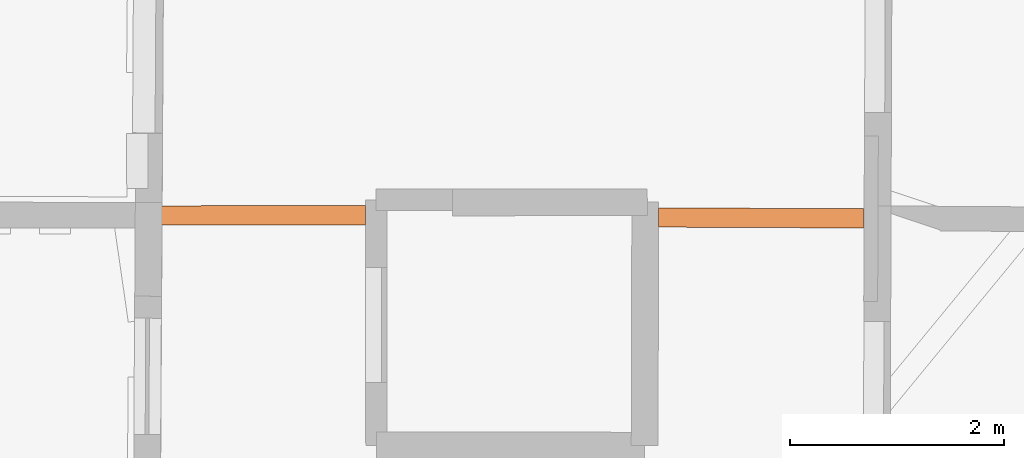
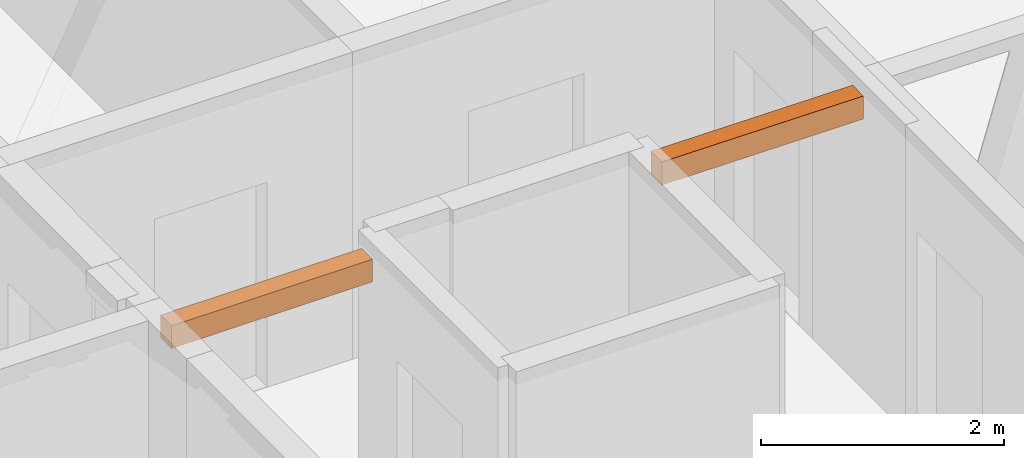
# One storey, part 15 of 15: 2 proxies.
"""IFC2X3 building model written with IfcOpenShell, lengths in metres."""

from ifc_helpers import new_model, entity, si_unit, converted_unit, derived_unit, direction, frame, origin, place, context, subcontext, project, spatial, polyline, outline, extrude, source, transform, mapped, material, type_object, type_shapes, element, save


model = new_model("IFC2X3")

# Units and contexts
model_context = context("Model", 3, precision=1e-05, world=origin(), true_north=direction((0.0, 1.0)))
body_context = subcontext(model_context, "Body", "Model", "MODEL_VIEW")
ifc_project = project(units=[si_unit("LENGTHUNIT", "METRE"), si_unit("AREAUNIT", "SQUARE_METRE"), si_unit("VOLUMEUNIT", "CUBIC_METRE"), converted_unit("PLANEANGLEUNIT", "DEGREE", entity("IfcRatioMeasure", 0.0174532925199433), si_unit("PLANEANGLEUNIT", "RADIAN"), dimensions=[0, 0, 0, 0, 0, 0, 0]), si_unit("MASSUNIT", "GRAM", prefix="KILO"), derived_unit("MASSDENSITYUNIT", [(si_unit("MASSUNIT", "GRAM", prefix="KILO"), 1), (si_unit("LENGTHUNIT", "METRE"), -3)]), derived_unit("MOMENTOFINERTIAUNIT", [(si_unit("LENGTHUNIT", "METRE"), 4)]), si_unit("TIMEUNIT", "SECOND"), si_unit("FREQUENCYUNIT", "HERTZ"), si_unit("THERMODYNAMICTEMPERATUREUNIT", "DEGREE_CELSIUS"), derived_unit("THERMALTRANSMITTANCEUNIT", [(si_unit("MASSUNIT", "GRAM", prefix="KILO"), 1), (si_unit("THERMODYNAMICTEMPERATUREUNIT", "KELVIN"), -1), (si_unit("TIMEUNIT", "SECOND"), -3)]), derived_unit("VOLUMETRICFLOWRATEUNIT", [(si_unit("LENGTHUNIT", "METRE"), 3), (si_unit("TIMEUNIT", "SECOND"), -1)]), si_unit("ELECTRICCURRENTUNIT", "AMPERE"), si_unit("ELECTRICVOLTAGEUNIT", "VOLT"), si_unit("POWERUNIT", "WATT"), si_unit("FORCEUNIT", "NEWTON", prefix="KILO"), si_unit("ILLUMINANCEUNIT", "LUX"), si_unit("LUMINOUSFLUXUNIT", "LUMEN"), si_unit("LUMINOUSINTENSITYUNIT", "CANDELA"), derived_unit("USERDEFINED", [(si_unit("MASSUNIT", "GRAM", prefix="KILO"), -1), (si_unit("LENGTHUNIT", "METRE"), -2), (si_unit("TIMEUNIT", "SECOND"), 3), (si_unit("LUMINOUSFLUXUNIT", "LUMEN"), 1)]), derived_unit("LINEARVELOCITYUNIT", [(si_unit("LENGTHUNIT", "METRE"), 1), (si_unit("TIMEUNIT", "SECOND"), -1)]), si_unit("PRESSUREUNIT", "PASCAL"), derived_unit("USERDEFINED", [(si_unit("LENGTHUNIT", "METRE"), -2), (si_unit("MASSUNIT", "GRAM", prefix="KILO"), 1), (si_unit("TIMEUNIT", "SECOND"), -2)]), derived_unit("LINEARFORCEUNIT", [(si_unit("MASSUNIT", "GRAM", prefix="KILO"), 1), (si_unit("LENGTHUNIT", "METRE"), 1), (si_unit("TIMEUNIT", "SECOND"), -2), (si_unit("LENGTHUNIT", "METRE"), -1)]), derived_unit("PLANARFORCEUNIT", [(si_unit("MASSUNIT", "GRAM", prefix="KILO"), 1), (si_unit("LENGTHUNIT", "METRE"), 1), (si_unit("TIMEUNIT", "SECOND"), -2), (si_unit("LENGTHUNIT", "METRE"), -2)])], contexts=[model_context])

# Site, building, storey
placement_1 = place(None, origin())
site = spatial("IfcSite", under=ifc_project, at=placement_1, CompositionType="ELEMENT")
building = spatial("IfcBuilding", under=site, at=placement_1, CompositionType="ELEMENT")
storey_placement = place(placement_1, frame((0.0, 0.0, 2.3807327747345)))
storey = spatial("IfcBuildingStorey", under=building, at=storey_placement, Name="Level 2", CompositionType="ELEMENT", Elevation=2.3807327747345)

# Proxies
ifc_material = material(Name="Beam default")
building_element_proxy_type_1 = type_object("IfcBuildingElementProxyType", Name="Beam:242", PredefinedType="NOTDEFINED")
shared_shape_1 = source(origin(), body_context, "Body", "SweptSolid", [
    extrude(outline(polyline([(1.9111840070427, -0.0900000035762787), (1.9111840070427, 0.0900000035762787), (0.0, 0.0900000035762787), (0.0, -0.0900000035762787), (1.9111840070427, -0.0900000035762787)])), origin(), (0.0, 0.0, 1.0), 0.226999759674072),
])
type_shapes(building_element_proxy_type_1, [shared_shape_1])
placement_2 = place(placement_1, frame((0.0, 0.0, 5.08500003814697)))
proxy_1_placement = place(placement_2, frame((3.09340378376792, 57.6459386711587, 0.0), z_axis=(0.0, 0.0, 1.0), x_axis=(0.999999410500986, 0.00108581659581334, 0.0)))
element("IfcBuildingElementProxy", 1, at=proxy_1_placement, inside=storey, type_object=building_element_proxy_type_1, material=ifc_material, Name="Beam:242", ObjectType="Beam", context=body_context, shape_type="MappedRepresentation", body=[
    mapped(shared_shape_1, transform((0.0, 0.0, 0.0), scale=1.0)),
])
building_element_proxy_type_2 = type_object("IfcBuildingElementProxyType", Name="Beam:649", PredefinedType="NOTDEFINED")
shared_shape_2 = source(origin(), body_context, "Body", "SweptSolid", [
    extrude(outline(polyline([(1.91180269287812, -0.0900000035762787), (1.91180269287812, 0.0900000035762787), (0.0, 0.0900000035762787), (0.0, -0.0900000035762787), (1.91180269287812, -0.0900000035762787)])), origin(), (0.0, 0.0, 1.0), 0.23199987411499),
])
type_shapes(building_element_proxy_type_2, [shared_shape_2])
placement_3 = place(placement_1, frame((0.0, 0.0, 5.11100006103516)))
proxy_2_placement = place(placement_3, frame((7.74306809433642, 57.6267689987531, 0.0), z_axis=(0.0, 0.0, 1.0), x_axis=(0.999990312378948, -0.00440172105590042, 0.0)))
element("IfcBuildingElementProxy", 2, at=proxy_2_placement, inside=storey, type_object=building_element_proxy_type_2, material=ifc_material, Name="Beam:649", ObjectType="Beam", context=body_context, shape_type="MappedRepresentation", body=[
    mapped(shared_shape_2, transform((0.0, 0.0, 0.0), scale=1.0)),
])

save(model, "model.ifc")
